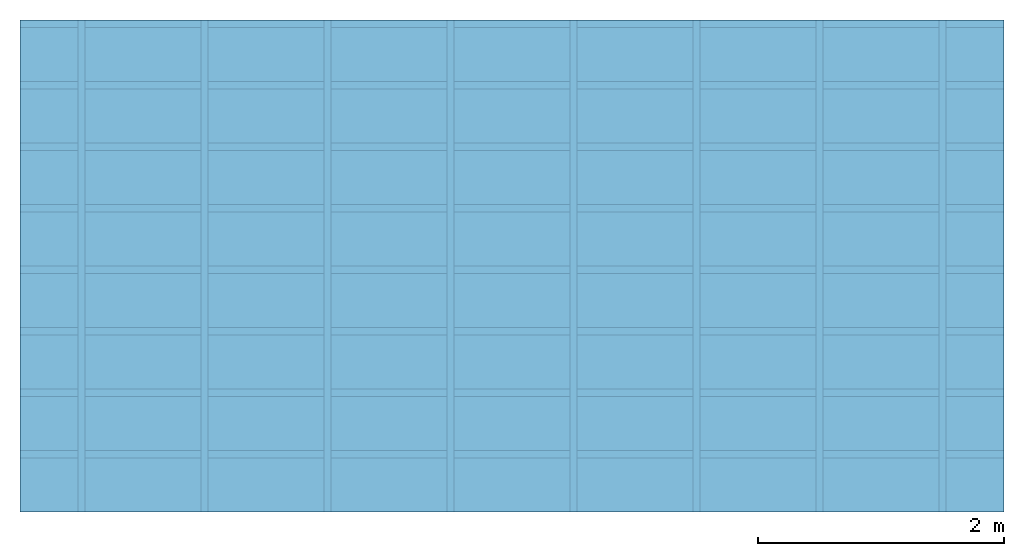
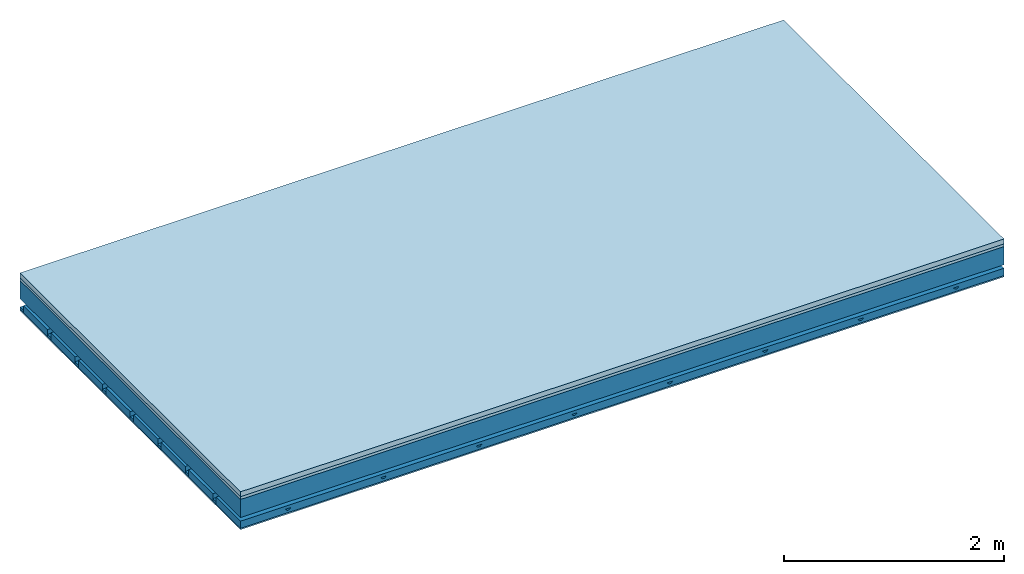
# One storey: 4 members, 3 plates, 1 element without a shape of its own.
"""IFC4 building model written with IfcOpenShell, lengths in metres."""

from ifc_helpers import new_model, si_unit, derived_unit, direction, frame, frame_2d, origin, origin_with_axes, place, context, project, spatial, polyline, rectangle, outline, extrude, material, layer, layer_set, type_object, element, aggregate, save


model = new_model("IFC4")

# Units and contexts
plan_context = context("Plan", 3, precision=1e-05, world=origin(), true_north=direction((0.0, 1.0)))
model_context = context("Model", 3, precision=1e-05, world=origin(), true_north=direction((0.0, 1.0)))
ifc_project = project(units=[si_unit("LENGTHUNIT", "METRE"), derived_unit("SOUNDPRESSUREUNIT", [(si_unit("PRESSUREUNIT", "PASCAL", prefix="MICRO"), 0)]), si_unit("ENERGYUNIT", "JOULE", prefix="MEGA"), si_unit("MASSUNIT", "GRAM", prefix="KILO"), derived_unit("THERMALTRANSMITTANCEUNIT", [(si_unit("POWERUNIT", "WATT"), 1), (si_unit("AREAUNIT", "SQUARE_METRE"), -1), (si_unit("THERMODYNAMICTEMPERATUREUNIT", "KELVIN"), -1)]), derived_unit("AREADENSITYUNIT", [(si_unit("MASSUNIT", "GRAM", prefix="KILO"), 1), (si_unit("AREAUNIT", "SQUARE_METRE"), -1)]), derived_unit("USERDEFINED", [(si_unit("ENERGYUNIT", "JOULE", prefix="MEGA"), 1), (si_unit("AREAUNIT", "SQUARE_METRE"), -1)])], contexts=[plan_context, model_context])

# Site, building, storey
site = spatial("IfcSite", under=ifc_project)
building_placement = place(None, origin())
building = spatial("IfcBuilding", under=site, at=building_placement)
storey_placement = place(building_placement, origin())
storey = spatial("IfcBuildingStorey", under=building, at=storey_placement)

# Slab, members, plates
ifc_material_1 = material(Category="04.005")
ifc_layer_1 = layer(ifc_material_1, 0.055, Name="On-material")
ifc_material_2 = material()
ifc_layer_2 = layer(ifc_material_2, 0.03, Name="Impact sound insulation")
ifc_layer_3 = layer(None, 0.2, Name="Supporting structure")
ifc_material_3 = material(Name="no composite action")
ifc_layer_4 = layer(ifc_material_3, 0.0, Name="Bond")
ifc_layer_5 = layer(None, 0.093, Name="Coupling")
ifc_layer_6 = layer(None, 0.027, Name="Battens / profiles")
ifc_material_4 = material(Name="Plasterboard type A", Category="03.008")
ifc_layer_7 = layer(ifc_material_4, 0.015, Name="Ceiling covering 1st layer")
ifc_material_5 = material(Name="joints", Category="04.017")
ifc_layer_8 = layer(ifc_material_5, 0.0, Name="Surface / treatment")
ifc_layer_set = layer_set([ifc_layer_1, ifc_layer_2, ifc_layer_3, ifc_layer_4, ifc_layer_5, ifc_layer_6, ifc_layer_7, ifc_layer_8])
slab_type = type_object("IfcSlabType", Name="A0904", PredefinedType="NOTDEFINED", material=ifc_layer_set)
slab_placement = place(None, frame((0.0, 0.0, 0.0), z_axis=(0.0, 0.0, -1.0), x_axis=(1.0, 0.0, 0.0)))
slab = element("IfcSlab", 1, at=slab_placement, inside=storey, type_object=slab_type, material=ifc_layer_set, Name="Slab #1")
ifc_material_6 = material()
member_1_placement = place(slab_placement, origin())
member_1 = element("IfcMember", 2, at=member_1_placement, material=ifc_material_6, Name="Supporting structure", context=plan_context, shape_type="SweptSolid", body=[
    extrude(rectangle(XDim=1.0, YDim=0.2, at=frame_2d((0.5, 0.1), x_axis=(1.0, 0.0))), frame((0.0, 4.0, 0.085), z_axis=(0.0, -1.0, 0.0), x_axis=(1.0, 0.0, 0.0)), (0.0, 0.0, 1.0), 4.0),
    extrude(rectangle(XDim=1.0, YDim=0.2, at=frame_2d((0.5, 0.1), x_axis=(1.0, 0.0))), frame((1.0, 4.0, 0.085), z_axis=(0.0, -1.0, 0.0), x_axis=(1.0, 0.0, 0.0)), (0.0, 0.0, 1.0), 4.0),
    extrude(rectangle(XDim=1.0, YDim=0.2, at=frame_2d((0.5, 0.1), x_axis=(1.0, 0.0))), frame((2.0, 4.0, 0.085), z_axis=(0.0, -1.0, 0.0), x_axis=(1.0, 0.0, 0.0)), (0.0, 0.0, 1.0), 4.0),
    extrude(rectangle(XDim=1.0, YDim=0.2, at=frame_2d((0.5, 0.1), x_axis=(1.0, 0.0))), frame((3.0, 4.0, 0.085), z_axis=(0.0, -1.0, 0.0), x_axis=(1.0, 0.0, 0.0)), (0.0, 0.0, 1.0), 4.0),
    extrude(rectangle(XDim=1.0, YDim=0.2, at=frame_2d((0.5, 0.1), x_axis=(1.0, 0.0))), frame((4.0, 4.0, 0.085), z_axis=(0.0, -1.0, 0.0), x_axis=(1.0, 0.0, 0.0)), (0.0, 0.0, 1.0), 4.0),
    extrude(rectangle(XDim=1.0, YDim=0.2, at=frame_2d((0.5, 0.1), x_axis=(1.0, 0.0))), frame((5.0, 4.0, 0.085), z_axis=(0.0, -1.0, 0.0), x_axis=(1.0, 0.0, 0.0)), (0.0, 0.0, 1.0), 4.0),
    extrude(rectangle(XDim=1.0, YDim=0.2, at=frame_2d((0.5, 0.1), x_axis=(1.0, 0.0))), frame((6.0, 4.0, 0.085), z_axis=(0.0, -1.0, 0.0), x_axis=(1.0, 0.0, 0.0)), (0.0, 0.0, 1.0), 4.0),
    extrude(rectangle(XDim=1.0, YDim=0.2, at=frame_2d((0.5, 0.1), x_axis=(1.0, 0.0))), frame((7.0, 4.0, 0.085), z_axis=(0.0, -1.0, 0.0), x_axis=(1.0, 0.0, 0.0)), (0.0, 0.0, 1.0), 4.0),
])
ifc_material_7 = material()
member_2_placement = place(slab_placement, origin())
member_2 = element("IfcMember", 3, at=member_2_placement, material=ifc_material_7, Name="Coupling", context=plan_context, shape_type="SweptSolid", body=[
    extrude(outline(polyline([(0.0, 0.0), (0.06, 0.0), (0.04, 0.02), (0.02, 0.02), (0.0, 0.0)])), frame((0.47, 4.0, 0.358), z_axis=(0.0, -1.0, 0.0), x_axis=(1.0, 0.0, 0.0)), (0.0, 0.0, 1.0), 4.0),
    extrude(outline(polyline([(0.0, 0.0), (0.06, 0.0), (0.04, 0.02), (0.02, 0.02), (0.0, 0.0)])), frame((1.47, 4.0, 0.358), z_axis=(0.0, -1.0, 0.0), x_axis=(1.0, 0.0, 0.0)), (0.0, 0.0, 1.0), 4.0),
    extrude(outline(polyline([(0.0, 0.0), (0.06, 0.0), (0.04, 0.02), (0.02, 0.02), (0.0, 0.0)])), frame((2.47, 4.0, 0.358), z_axis=(0.0, -1.0, 0.0), x_axis=(1.0, 0.0, 0.0)), (0.0, 0.0, 1.0), 4.0),
    extrude(outline(polyline([(0.0, 0.0), (0.06, 0.0), (0.04, 0.02), (0.02, 0.02), (0.0, 0.0)])), frame((3.47, 4.0, 0.358), z_axis=(0.0, -1.0, 0.0), x_axis=(1.0, 0.0, 0.0)), (0.0, 0.0, 1.0), 4.0),
    extrude(outline(polyline([(0.0, 0.0), (0.06, 0.0), (0.04, 0.02), (0.02, 0.02), (0.0, 0.0)])), frame((4.47, 4.0, 0.358), z_axis=(0.0, -1.0, 0.0), x_axis=(1.0, 0.0, 0.0)), (0.0, 0.0, 1.0), 4.0),
    extrude(outline(polyline([(0.0, 0.0), (0.06, 0.0), (0.04, 0.02), (0.02, 0.02), (0.0, 0.0)])), frame((5.47, 4.0, 0.358), z_axis=(0.0, -1.0, 0.0), x_axis=(1.0, 0.0, 0.0)), (0.0, 0.0, 1.0), 4.0),
    extrude(outline(polyline([(0.0, 0.0), (0.06, 0.0), (0.04, 0.02), (0.02, 0.02), (0.0, 0.0)])), frame((6.47, 4.0, 0.358), z_axis=(0.0, -1.0, 0.0), x_axis=(1.0, 0.0, 0.0)), (0.0, 0.0, 1.0), 4.0),
    extrude(outline(polyline([(0.0, 0.0), (0.06, 0.0), (0.04, 0.02), (0.02, 0.02), (0.0, 0.0)])), frame((7.47, 4.0, 0.358), z_axis=(0.0, -1.0, 0.0), x_axis=(1.0, 0.0, 0.0)), (0.0, 0.0, 1.0), 4.0),
])
ifc_material_8 = material()
member_3_placement = place(slab_placement, origin())
member_3 = element("IfcMember", 4, at=member_3_placement, material=ifc_material_8, Name="Battens / profiles", context=plan_context, shape_type="SweptSolid", body=[
    extrude(rectangle(XDim=0.06, YDim=0.027, at=frame_2d((0.03, 0.0135), x_axis=(1.0, 0.0))), frame((0.0, 0.0, 0.378), z_axis=(1.0, 0.0, 0.0), x_axis=(0.0, 1.0, 0.0)), (0.0, 0.0, 1.0), 8.0),
    extrude(rectangle(XDim=0.06, YDim=0.027, at=frame_2d((0.03, 0.0135), x_axis=(1.0, 0.0))), frame((0.0, 0.5, 0.378), z_axis=(1.0, 0.0, 0.0), x_axis=(0.0, 1.0, 0.0)), (0.0, 0.0, 1.0), 8.0),
    extrude(rectangle(XDim=0.06, YDim=0.027, at=frame_2d((0.03, 0.0135), x_axis=(1.0, 0.0))), frame((0.0, 1.0, 0.378), z_axis=(1.0, 0.0, 0.0), x_axis=(0.0, 1.0, 0.0)), (0.0, 0.0, 1.0), 8.0),
    extrude(rectangle(XDim=0.06, YDim=0.027, at=frame_2d((0.03, 0.0135), x_axis=(1.0, 0.0))), frame((0.0, 1.5, 0.378), z_axis=(1.0, 0.0, 0.0), x_axis=(0.0, 1.0, 0.0)), (0.0, 0.0, 1.0), 8.0),
    extrude(rectangle(XDim=0.06, YDim=0.027, at=frame_2d((0.03, 0.0135), x_axis=(1.0, 0.0))), frame((0.0, 2.0, 0.378), z_axis=(1.0, 0.0, 0.0), x_axis=(0.0, 1.0, 0.0)), (0.0, 0.0, 1.0), 8.0),
    extrude(rectangle(XDim=0.06, YDim=0.027, at=frame_2d((0.03, 0.0135), x_axis=(1.0, 0.0))), frame((0.0, 2.5, 0.378), z_axis=(1.0, 0.0, 0.0), x_axis=(0.0, 1.0, 0.0)), (0.0, 0.0, 1.0), 8.0),
    extrude(rectangle(XDim=0.06, YDim=0.027, at=frame_2d((0.03, 0.0135), x_axis=(1.0, 0.0))), frame((0.0, 3.0, 0.378), z_axis=(1.0, 0.0, 0.0), x_axis=(0.0, 1.0, 0.0)), (0.0, 0.0, 1.0), 8.0),
    extrude(rectangle(XDim=0.06, YDim=0.027, at=frame_2d((0.03, 0.0135), x_axis=(1.0, 0.0))), frame((0.0, 3.5, 0.378), z_axis=(1.0, 0.0, 0.0), x_axis=(0.0, 1.0, 0.0)), (0.0, 0.0, 1.0), 8.0),
])
ifc_material_9 = material()
member_4_placement = place(slab_placement, origin())
member_4 = element("IfcMember", 5, at=member_4_placement, material=ifc_material_9, Name="Cavity", context=plan_context, shape_type="SweptSolid", body=[
    extrude(rectangle(XDim=0.44, YDim=0.08, at=frame_2d((0.22, 0.04), x_axis=(1.0, 0.0))), frame((0.0, 0.06, 0.325), z_axis=(1.0, 0.0, 0.0), x_axis=(0.0, 1.0, 0.0)), (0.0, 0.0, 1.0), 8.0),
    extrude(rectangle(XDim=0.44, YDim=0.08, at=frame_2d((0.22, 0.04), x_axis=(1.0, 0.0))), frame((0.0, 0.56, 0.325), z_axis=(1.0, 0.0, 0.0), x_axis=(0.0, 1.0, 0.0)), (0.0, 0.0, 1.0), 8.0),
    extrude(rectangle(XDim=0.44, YDim=0.08, at=frame_2d((0.22, 0.04), x_axis=(1.0, 0.0))), frame((0.0, 1.06, 0.325), z_axis=(1.0, 0.0, 0.0), x_axis=(0.0, 1.0, 0.0)), (0.0, 0.0, 1.0), 8.0),
    extrude(rectangle(XDim=0.44, YDim=0.08, at=frame_2d((0.22, 0.04), x_axis=(1.0, 0.0))), frame((0.0, 1.56, 0.325), z_axis=(1.0, 0.0, 0.0), x_axis=(0.0, 1.0, 0.0)), (0.0, 0.0, 1.0), 8.0),
    extrude(rectangle(XDim=0.44, YDim=0.08, at=frame_2d((0.22, 0.04), x_axis=(1.0, 0.0))), frame((0.0, 2.06, 0.325), z_axis=(1.0, 0.0, 0.0), x_axis=(0.0, 1.0, 0.0)), (0.0, 0.0, 1.0), 8.0),
    extrude(rectangle(XDim=0.44, YDim=0.08, at=frame_2d((0.22, 0.04), x_axis=(1.0, 0.0))), frame((0.0, 2.56, 0.325), z_axis=(1.0, 0.0, 0.0), x_axis=(0.0, 1.0, 0.0)), (0.0, 0.0, 1.0), 8.0),
    extrude(rectangle(XDim=0.44, YDim=0.08, at=frame_2d((0.22, 0.04), x_axis=(1.0, 0.0))), frame((0.0, 3.06, 0.325), z_axis=(1.0, 0.0, 0.0), x_axis=(0.0, 1.0, 0.0)), (0.0, 0.0, 1.0), 8.0),
    extrude(rectangle(XDim=0.44, YDim=0.08, at=frame_2d((0.22, 0.04), x_axis=(1.0, 0.0))), frame((0.0, 3.56, 0.325), z_axis=(1.0, 0.0, 0.0), x_axis=(0.0, 1.0, 0.0)), (0.0, 0.0, 1.0), 8.0),
])
plate_1_placement = place(slab_placement, origin())
plate_1 = element("IfcPlate", 6, at=plate_1_placement, material=ifc_material_1, Name="On-material", context=plan_context, shape_type="SweptSolid", body=[
    extrude(rectangle(XDim=8.0, YDim=4.0, at=frame_2d((4.0, 2.0), x_axis=(1.0, 0.0))), origin_with_axes(), (0.0, 0.0, 1.0), 0.055),
])
plate_2_placement = place(slab_placement, origin())
plate_2 = element("IfcPlate", 7, at=plate_2_placement, material=ifc_material_2, Name="Impact sound insulation", context=plan_context, shape_type="SweptSolid", body=[
    extrude(rectangle(XDim=8.0, YDim=4.0, at=frame_2d((4.0, 2.0), x_axis=(1.0, 0.0))), frame((0.0, 0.0, 0.055), z_axis=(0.0, 0.0, 1.0), x_axis=(1.0, 0.0, 0.0)), (0.0, 0.0, 1.0), 0.03),
])
plate_3_placement = place(slab_placement, origin())
plate_3 = element("IfcPlate", 8, at=plate_3_placement, material=ifc_material_4, Name="Ceiling covering 1st layer", context=plan_context, shape_type="SweptSolid", body=[
    extrude(rectangle(XDim=8.0, YDim=4.0, at=frame_2d((4.0, 2.0), x_axis=(1.0, 0.0))), frame((0.0, 0.0, 0.405), z_axis=(0.0, 0.0, 1.0), x_axis=(1.0, 0.0, 0.0)), (0.0, 0.0, 1.0), 0.015),
])
aggregate(slab, [plate_1, plate_2, member_1, member_2, member_3, member_4, plate_3])

save(model, "model.ifc")
